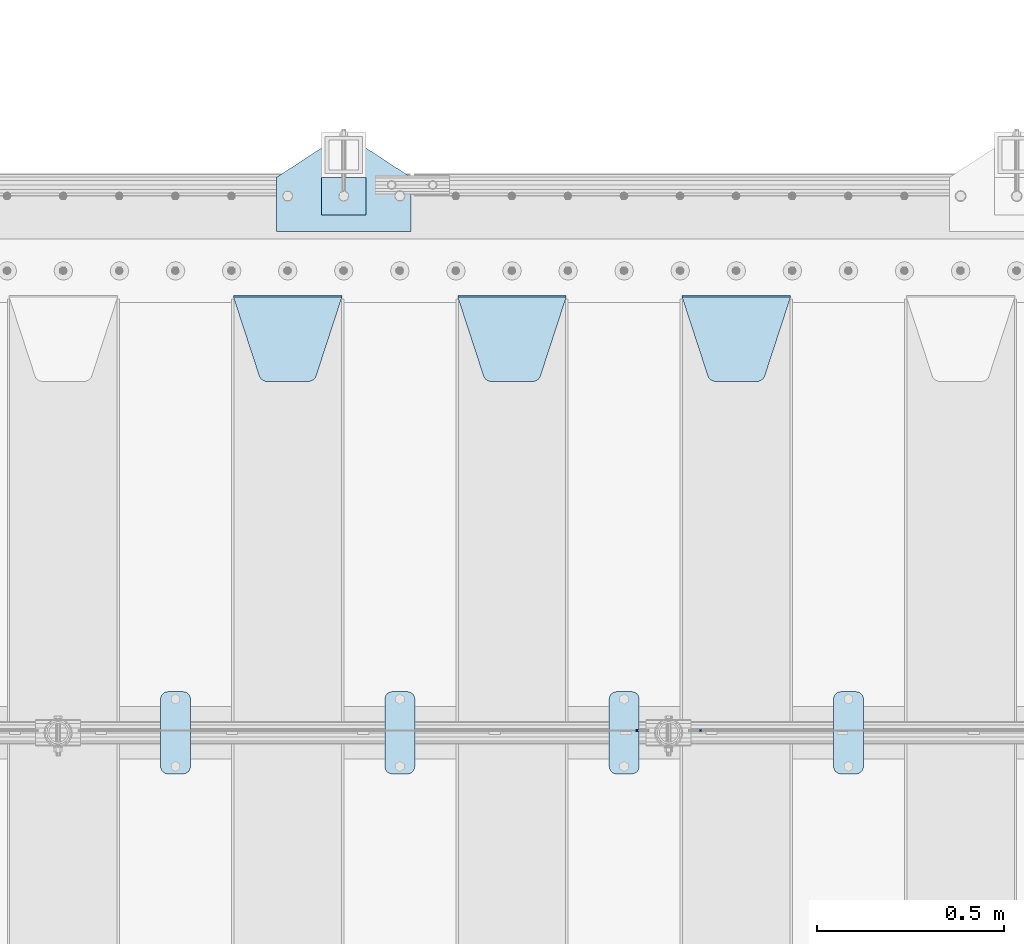
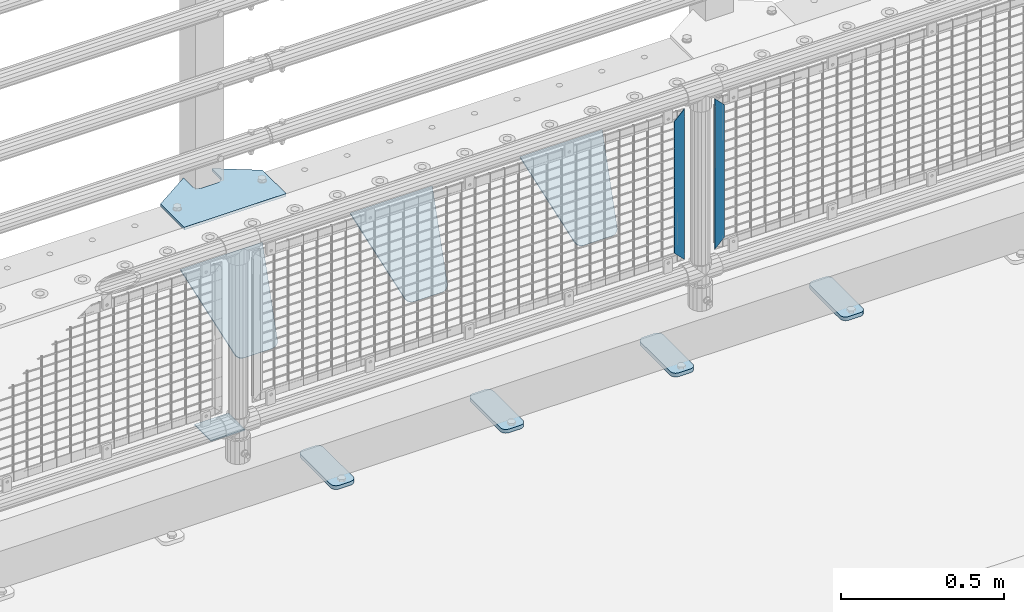
# One storey, part 235 of 270: 11 plates.
"""IFC2X3 building model written with IfcOpenShell, lengths in millimetres."""

from ifc_helpers import new_model, si_unit, frame, origin_with_axes, place, context, subcontext, project, spatial, faceted_brep, material, type_object, element, save


model = new_model("IFC2X3")

# Units and contexts
model_context = context("Model", 3, precision=1e-05, world=origin_with_axes())
body_context = subcontext(model_context, "Body", "Model", "MODEL_VIEW")
ifc_project = project(units=[si_unit("LENGTHUNIT", "METRE", prefix="MILLI"), si_unit("AREAUNIT", "SQUARE_METRE"), si_unit("VOLUMEUNIT", "CUBIC_METRE"), si_unit("MASSUNIT", "GRAM", prefix="KILO"), si_unit("TIMEUNIT", "SECOND"), si_unit("PLANEANGLEUNIT", "RADIAN"), si_unit("SOLIDANGLEUNIT", "STERADIAN"), si_unit("THERMODYNAMICTEMPERATUREUNIT", "DEGREE_CELSIUS"), si_unit("LUMINOUSINTENSITYUNIT", "LUMEN")], contexts=[model_context])

# Site, building, storey
site_placement = place(None, origin_with_axes())
site = spatial("IfcSite", under=ifc_project, at=site_placement, CompositionType="ELEMENT")
building_placement = place(site_placement, origin_with_axes())
building = spatial("IfcBuilding", under=site, at=building_placement, Name="Standard", CompositionType="ELEMENT")
storey_placement = place(building_placement, origin_with_axes())
storey = spatial("IfcBuildingStorey", under=building, at=storey_placement, Name="Undefined", CompositionType="ELEMENT", Elevation=0.0)

# Plates
ifc_material_1 = material(Name="STEEL/S355J2")
plate_type_1 = type_object("IfcPlateType", PredefinedType="NOTDEFINED")
plate_1_placement = place(storey_placement, frame((9370.0, -14995.0, 5.00000000004911), z_axis=(0.0, 1.0, 0.0), x_axis=(1.0, 0.0, 0.0)))
element("IfcPlate", 1, at=plate_1_placement, inside=storey, type_object=plate_type_1, material=ifc_material_1, context=body_context, shape_type="Brep", body=[
    faceted_brep([(0.0, -5.0, 0.0), (2.31396552408114e-06, -5.0, 145.0), (2.31396552408114e-06, 5.0, 145.0), (0.0, 5.0, 0.0), (130.0, -5.0, 230.0), (130.0, 5.0, 230.0), (130.0, -5.0, 180.0), (130.0, 5.0, 180.0), (130.48036798992, -5.0, 175.122741949597), (130.48036798992, 5.0, 175.122741949597), (131.903011687216, -5.0, 170.432914190873), (131.903011687216, 5.0, 170.432914190873), (134.213259692435, -5.0, 166.11074417451), (134.213259692435, 5.0, 166.11074417451), (137.322330470335, -5.0, 162.322330470337), (137.322330470335, 5.0, 162.322330470337), (141.110744174512, -5.0, 159.213259692437), (141.110744174512, 5.0, 159.213259692437), (145.432914190871, -5.0, 156.903011687218), (145.432914190871, 5.0, 156.903011687218), (150.122741949595, -5.0, 155.48036798992), (150.122741949595, 5.0, 155.48036798992), (155.0, -5.0, 155.0), (155.0, 5.0, 155.0), (205.0, -5.0, 155.0), (205.0, 5.0, 155.0), (209.877258050405, -5.0, 155.48036798992), (209.877258050405, 5.0, 155.48036798992), (214.567085809129, -5.0, 156.903011687218), (214.567085809129, 5.0, 156.903011687218), (218.889255825488, -5.0, 159.213259692437), (218.889255825488, 5.0, 159.213259692437), (222.677669529665, -5.0, 162.322330470337), (222.677669529665, 5.0, 162.322330470337), (225.786740307565, -5.0, 166.11074417451), (225.786740307565, 5.0, 166.11074417451), (228.096988312784, -5.0, 170.432914190873), (228.096988312784, 5.0, 170.432914190873), (229.51963201008, -5.0, 175.122741949597), (229.51963201008, 5.0, 175.122741949597), (230.0, -5.0, 180.0), (230.0, 5.0, 180.0), (230.0, -5.0, 230.0), (230.0, 5.0, 230.0), (360.0, -5.0, 145.0), (360.0, 5.0, 145.0), (360.0, -5.0, -7.27595761418343e-12), (360.0, 5.0, -7.27595761418343e-12)], [[[0, 1, 2, 3]], [[1, 4, 5, 2]], [[4, 6, 7, 5]], [[6, 8, 9, 7]], [[8, 10, 11, 9]], [[10, 12, 13, 11]], [[12, 14, 15, 13]], [[14, 16, 17, 15]], [[16, 18, 19, 17]], [[18, 20, 21, 19]], [[20, 22, 23, 21]], [[22, 24, 25, 23]], [[24, 26, 27, 25]], [[26, 28, 29, 27]], [[28, 30, 31, 29]], [[30, 32, 33, 31]], [[32, 34, 35, 33]], [[34, 36, 37, 35]], [[36, 38, 39, 37]], [[38, 40, 41, 39]], [[40, 42, 43, 41]], [[42, 44, 45, 43]], [[44, 46, 47, 45]], [[46, 0, 3, 47]], [[5, 7, 9, 11, 13, 15, 17, 19, 21, 23, 25, 27, 29, 31, 33, 35, 37, 39, 41, 43, 45, 47, 3, 2]], [[46, 44, 42, 40, 38, 36, 34, 32, 30, 28, 26, 24, 22, 20, 18, 16, 14, 12, 10, 8, 6, 4, 1, 0]]]),
])
plate_type_2 = type_object("IfcPlateType", PredefinedType="NOTDEFINED")
plate_2_placement = place(storey_placement, frame((9490.00000000014, -14949.9999999998, -857.500000000002), z_axis=(0.0, 1.0, 0.0), x_axis=(1.0, 0.0, 0.0)))
element("IfcPlate", 2, at=plate_2_placement, inside=storey, type_object=plate_type_2, material=ifc_material_1, context=body_context, shape_type="Brep", body=[
    faceted_brep([(0.0, -2.5, 0.0), (0.0, -2.5, 100.0), (0.0, 2.5, 100.0), (0.0, 2.5, 0.0), (120.0, -2.5, 100.0), (120.0, 2.5, 100.0), (120.0, -2.5, 0.0), (120.0, 2.5, 0.0)], [[[0, 1, 2, 3]], [[1, 4, 5, 2]], [[4, 6, 7, 5]], [[6, 0, 3, 7]], [[5, 7, 3, 2]], [[6, 4, 1, 0]]]),
])
plate_type_3 = type_object("IfcPlateType", PredefinedType="NOTDEFINED")
plate_3_placement = place(storey_placement, frame((10860.0, -16225.5, 21.0199999999977), z_axis=(1.0, 0.0, 0.0), x_axis=(0.0, -1.0, 0.0)))
element("IfcPlate", 3, at=plate_3_placement, inside=storey, type_object=plate_type_3, material=ifc_material_1, context=body_context, shape_type="Brep", body=[
    faceted_brep([(0.0, -7.0, 20.0), (0.0, -7.0, 60.0), (0.0, 7.0, 60.0), (0.0, 7.0, 20.0), (0.384294391937146, -7.0, 63.9018064403208), (0.384294391937146, 7.0, 63.9018064403208), (1.52240934977453, -7.0, 67.6536686473009), (1.52240934977453, 7.0, 67.6536686473009), (3.37060775395003, -7.0, 71.1114046603907), (3.37060775395003, 7.0, 71.1114046603907), (5.8578643762703, -7.0, 74.1421356237297), (5.8578643762703, 7.0, 74.1421356237297), (8.88859533960931, -7.0, 76.62939224605), (8.88859533960931, 7.0, 76.62939224605), (12.3463313526991, -7.0, 78.4775906502255), (12.3463313526991, 7.0, 78.4775906502255), (16.0981935596792, -7.0, 79.6157056080629), (16.0981935596792, 7.0, 79.6157056080629), (20.0, -7.0, 80.0), (20.0, 7.0, 80.0), (200.0, -7.0, 80.0), (200.0, 7.0, 80.0), (203.901806440321, -7.0, 79.6157056080629), (203.901806440321, 7.0, 79.6157056080629), (207.653668647301, -7.0, 78.4775906502255), (207.653668647301, 7.0, 78.4775906502255), (211.111404660391, -7.0, 76.62939224605), (211.111404660391, 7.0, 76.62939224605), (214.142135623733, -7.0, 74.1421356237297), (214.142135623733, 7.0, 74.1421356237297), (216.629392246054, -7.0, 71.1114046603907), (216.629392246054, 7.0, 71.1114046603907), (218.477590650225, -7.0, 67.6536686473009), (218.477590650225, 7.0, 67.6536686473009), (219.615705608063, -7.0, 63.9018064403208), (219.615705608063, 7.0, 63.9018064403208), (220.0, -7.0, 60.0), (220.0, 7.0, 60.0), (220.0, -7.0, 20.0), (220.0, 7.0, 20.0), (219.615705608063, -7.0, 16.0981935596792), (219.615705608063, 7.0, 16.0981935596792), (218.477590650225, -7.0, 12.3463313526991), (218.477590650225, 7.0, 12.3463313526991), (216.629392246054, -7.0, 8.88859533960931), (216.629392246054, 7.0, 8.88859533960931), (214.142135623733, -7.0, 5.8578643762703), (214.142135623733, 7.0, 5.8578643762703), (211.111404660391, -7.0, 3.37060775395003), (211.111404660391, 7.0, 3.37060775395003), (207.653668647301, -7.0, 1.52240934977453), (207.653668647301, 7.0, 1.52240934977453), (203.901806440321, -7.0, 0.384294391937146), (203.901806440321, 7.0, 0.384294391937146), (200.0, -7.0, 0.0), (200.0, 7.0, 0.0), (20.0, -7.0, 0.0), (20.0, 7.0, 0.0), (16.0981935596792, -7.0, 0.384294391937146), (16.0981935596792, 7.0, 0.384294391937146), (12.3463313526991, -7.0, 1.52240934977453), (12.3463313526991, 7.0, 1.52240934977453), (8.88859533960931, -7.0, 3.37060775395003), (8.88859533960931, 7.0, 3.37060775395003), (5.8578643762703, -7.0, 5.8578643762703), (5.8578643762703, 7.0, 5.8578643762703), (3.37060775395003, -7.0, 8.88859533960931), (3.37060775395003, 7.0, 8.88859533960931), (1.52240934977453, -7.0, 12.3463313526991), (1.52240934977453, 7.0, 12.3463313526991), (0.384294391937146, -7.0, 16.0981935596792), (0.384294391937146, 7.0, 16.0981935596792)], [[[0, 1, 2, 3]], [[1, 4, 5, 2]], [[4, 6, 7, 5]], [[6, 8, 9, 7]], [[8, 10, 11, 9]], [[10, 12, 13, 11]], [[12, 14, 15, 13]], [[14, 16, 17, 15]], [[16, 18, 19, 17]], [[18, 20, 21, 19]], [[20, 22, 23, 21]], [[22, 24, 25, 23]], [[24, 26, 27, 25]], [[26, 28, 29, 27]], [[28, 30, 31, 29]], [[30, 32, 33, 31]], [[32, 34, 35, 33]], [[34, 36, 37, 35]], [[36, 38, 39, 37]], [[38, 40, 41, 39]], [[40, 42, 43, 41]], [[42, 44, 45, 43]], [[44, 46, 47, 45]], [[46, 48, 49, 47]], [[48, 50, 51, 49]], [[50, 52, 53, 51]], [[52, 54, 55, 53]], [[54, 56, 57, 55]], [[56, 58, 59, 57]], [[58, 60, 61, 59]], [[60, 62, 63, 61]], [[62, 64, 65, 63]], [[64, 66, 67, 65]], [[66, 68, 69, 67]], [[68, 70, 71, 69]], [[70, 0, 3, 71]], [[5, 7, 9, 11, 13, 15, 17, 19, 21, 23, 25, 27, 29, 31, 33, 35, 37, 39, 41, 43, 45, 47, 49, 51, 53, 55, 57, 59, 61, 63, 65, 67, 69, 71, 3, 2]], [[70, 68, 66, 64, 62, 60, 58, 56, 54, 52, 50, 48, 46, 44, 42, 40, 38, 36, 34, 32, 30, 28, 26, 24, 22, 20, 18, 16, 14, 12, 10, 8, 6, 4, 1, 0]]]),
])
plate_4_placement = place(storey_placement, frame((10260.0, -16225.5, 21.0199999999977), z_axis=(1.0, 0.0, 0.0), x_axis=(0.0, -1.0, 0.0)))
element("IfcPlate", 4, at=plate_4_placement, inside=storey, type_object=plate_type_3, material=ifc_material_1, context=body_context, shape_type="Brep", body=[
    faceted_brep([(0.0, -7.0, 20.0), (0.0, -7.0, 60.0), (0.0, 7.0, 60.0), (0.0, 7.0, 20.0), (0.384294391937146, -7.0, 63.9018064403208), (0.384294391937146, 7.0, 63.9018064403208), (1.52240934977453, -7.0, 67.6536686473009), (1.52240934977453, 7.0, 67.6536686473009), (3.37060775395003, -7.0, 71.1114046603907), (3.37060775395003, 7.0, 71.1114046603907), (5.8578643762703, -7.0, 74.1421356237297), (5.8578643762703, 7.0, 74.1421356237297), (8.88859533960931, -7.0, 76.62939224605), (8.88859533960931, 7.0, 76.62939224605), (12.3463313526991, -7.0, 78.4775906502255), (12.3463313526991, 7.0, 78.4775906502255), (16.0981935596792, -7.0, 79.6157056080629), (16.0981935596792, 7.0, 79.6157056080629), (20.0, -7.0, 80.0), (20.0, 7.0, 80.0), (200.0, -7.0, 80.0), (200.0, 7.0, 80.0), (203.901806440321, -7.0, 79.6157056080629), (203.901806440321, 7.0, 79.6157056080629), (207.653668647301, -7.0, 78.4775906502255), (207.653668647301, 7.0, 78.4775906502255), (211.111404660391, -7.0, 76.62939224605), (211.111404660391, 7.0, 76.62939224605), (214.142135623733, -7.0, 74.1421356237297), (214.142135623733, 7.0, 74.1421356237297), (216.629392246054, -7.0, 71.1114046603907), (216.629392246054, 7.0, 71.1114046603907), (218.477590650225, -7.0, 67.6536686473009), (218.477590650225, 7.0, 67.6536686473009), (219.615705608063, -7.0, 63.9018064403208), (219.615705608063, 7.0, 63.9018064403208), (220.0, -7.0, 60.0), (220.0, 7.0, 60.0), (220.0, -7.0, 20.0), (220.0, 7.0, 20.0), (219.615705608063, -7.0, 16.0981935596792), (219.615705608063, 7.0, 16.0981935596792), (218.477590650225, -7.0, 12.3463313526991), (218.477590650225, 7.0, 12.3463313526991), (216.629392246054, -7.0, 8.88859533960931), (216.629392246054, 7.0, 8.88859533960931), (214.142135623733, -7.0, 5.8578643762703), (214.142135623733, 7.0, 5.8578643762703), (211.111404660391, -7.0, 3.37060775395003), (211.111404660391, 7.0, 3.37060775395003), (207.653668647301, -7.0, 1.52240934977453), (207.653668647301, 7.0, 1.52240934977453), (203.901806440321, -7.0, 0.384294391937146), (203.901806440321, 7.0, 0.384294391937146), (200.0, -7.0, 0.0), (200.0, 7.0, 0.0), (20.0, -7.0, 0.0), (20.0, 7.0, 0.0), (16.0981935596792, -7.0, 0.384294391937146), (16.0981935596792, 7.0, 0.384294391937146), (12.3463313526991, -7.0, 1.52240934977453), (12.3463313526991, 7.0, 1.52240934977453), (8.88859533960931, -7.0, 3.37060775395003), (8.88859533960931, 7.0, 3.37060775395003), (5.8578643762703, -7.0, 5.8578643762703), (5.8578643762703, 7.0, 5.8578643762703), (3.37060775395003, -7.0, 8.88859533960931), (3.37060775395003, 7.0, 8.88859533960931), (1.52240934977453, -7.0, 12.3463313526991), (1.52240934977453, 7.0, 12.3463313526991), (0.384294391937146, -7.0, 16.0981935596792), (0.384294391937146, 7.0, 16.0981935596792)], [[[0, 1, 2, 3]], [[1, 4, 5, 2]], [[4, 6, 7, 5]], [[6, 8, 9, 7]], [[8, 10, 11, 9]], [[10, 12, 13, 11]], [[12, 14, 15, 13]], [[14, 16, 17, 15]], [[16, 18, 19, 17]], [[18, 20, 21, 19]], [[20, 22, 23, 21]], [[22, 24, 25, 23]], [[24, 26, 27, 25]], [[26, 28, 29, 27]], [[28, 30, 31, 29]], [[30, 32, 33, 31]], [[32, 34, 35, 33]], [[34, 36, 37, 35]], [[36, 38, 39, 37]], [[38, 40, 41, 39]], [[40, 42, 43, 41]], [[42, 44, 45, 43]], [[44, 46, 47, 45]], [[46, 48, 49, 47]], [[48, 50, 51, 49]], [[50, 52, 53, 51]], [[52, 54, 55, 53]], [[54, 56, 57, 55]], [[56, 58, 59, 57]], [[58, 60, 61, 59]], [[60, 62, 63, 61]], [[62, 64, 65, 63]], [[64, 66, 67, 65]], [[66, 68, 69, 67]], [[68, 70, 71, 69]], [[70, 0, 3, 71]], [[5, 7, 9, 11, 13, 15, 17, 19, 21, 23, 25, 27, 29, 31, 33, 35, 37, 39, 41, 43, 45, 47, 49, 51, 53, 55, 57, 59, 61, 63, 65, 67, 69, 71, 3, 2]], [[70, 68, 66, 64, 62, 60, 58, 56, 54, 52, 50, 48, 46, 44, 42, 40, 38, 36, 34, 32, 30, 28, 26, 24, 22, 20, 18, 16, 14, 12, 10, 8, 6, 4, 1, 0]]]),
])
plate_5_placement = place(storey_placement, frame((9660.0, -16225.5, 21.0199999999977), z_axis=(1.0, 0.0, 0.0), x_axis=(0.0, -1.0, 0.0)))
element("IfcPlate", 5, at=plate_5_placement, inside=storey, type_object=plate_type_3, material=ifc_material_1, context=body_context, shape_type="Brep", body=[
    faceted_brep([(0.0, -7.0, 20.0), (0.0, -7.0, 60.0), (0.0, 7.0, 60.0), (0.0, 7.0, 20.0), (0.384294391937146, -7.0, 63.9018064403208), (0.384294391937146, 7.0, 63.9018064403208), (1.52240934977453, -7.0, 67.6536686473009), (1.52240934977453, 7.0, 67.6536686473009), (3.37060775395003, -7.0, 71.1114046603907), (3.37060775395003, 7.0, 71.1114046603907), (5.8578643762703, -7.0, 74.1421356237297), (5.8578643762703, 7.0, 74.1421356237297), (8.88859533960931, -7.0, 76.62939224605), (8.88859533960931, 7.0, 76.62939224605), (12.3463313526991, -7.0, 78.4775906502255), (12.3463313526991, 7.0, 78.4775906502255), (16.0981935596792, -7.0, 79.6157056080629), (16.0981935596792, 7.0, 79.6157056080629), (20.0, -7.0, 80.0), (20.0, 7.0, 80.0), (200.0, -7.0, 80.0), (200.0, 7.0, 80.0), (203.901806440321, -7.0, 79.6157056080629), (203.901806440321, 7.0, 79.6157056080629), (207.653668647301, -7.0, 78.4775906502255), (207.653668647301, 7.0, 78.4775906502255), (211.111404660391, -7.0, 76.62939224605), (211.111404660391, 7.0, 76.62939224605), (214.142135623733, -7.0, 74.1421356237297), (214.142135623733, 7.0, 74.1421356237297), (216.629392246054, -7.0, 71.1114046603907), (216.629392246054, 7.0, 71.1114046603907), (218.477590650225, -7.0, 67.6536686473009), (218.477590650225, 7.0, 67.6536686473009), (219.615705608063, -7.0, 63.9018064403208), (219.615705608063, 7.0, 63.9018064403208), (220.0, -7.0, 60.0), (220.0, 7.0, 60.0), (220.0, -7.0, 20.0), (220.0, 7.0, 20.0), (219.615705608063, -7.0, 16.0981935596792), (219.615705608063, 7.0, 16.0981935596792), (218.477590650225, -7.0, 12.3463313526991), (218.477590650225, 7.0, 12.3463313526991), (216.629392246054, -7.0, 8.88859533960931), (216.629392246054, 7.0, 8.88859533960931), (214.142135623733, -7.0, 5.8578643762703), (214.142135623733, 7.0, 5.8578643762703), (211.111404660391, -7.0, 3.37060775395003), (211.111404660391, 7.0, 3.37060775395003), (207.653668647301, -7.0, 1.52240934977453), (207.653668647301, 7.0, 1.52240934977453), (203.901806440321, -7.0, 0.384294391937146), (203.901806440321, 7.0, 0.384294391937146), (200.0, -7.0, 0.0), (200.0, 7.0, 0.0), (20.0, -7.0, 0.0), (20.0, 7.0, 0.0), (16.0981935596792, -7.0, 0.384294391937146), (16.0981935596792, 7.0, 0.384294391937146), (12.3463313526991, -7.0, 1.52240934977453), (12.3463313526991, 7.0, 1.52240934977453), (8.88859533960931, -7.0, 3.37060775395003), (8.88859533960931, 7.0, 3.37060775395003), (5.8578643762703, -7.0, 5.8578643762703), (5.8578643762703, 7.0, 5.8578643762703), (3.37060775395003, -7.0, 8.88859533960931), (3.37060775395003, 7.0, 8.88859533960931), (1.52240934977453, -7.0, 12.3463313526991), (1.52240934977453, 7.0, 12.3463313526991), (0.384294391937146, -7.0, 16.0981935596792), (0.384294391937146, 7.0, 16.0981935596792)], [[[0, 1, 2, 3]], [[1, 4, 5, 2]], [[4, 6, 7, 5]], [[6, 8, 9, 7]], [[8, 10, 11, 9]], [[10, 12, 13, 11]], [[12, 14, 15, 13]], [[14, 16, 17, 15]], [[16, 18, 19, 17]], [[18, 20, 21, 19]], [[20, 22, 23, 21]], [[22, 24, 25, 23]], [[24, 26, 27, 25]], [[26, 28, 29, 27]], [[28, 30, 31, 29]], [[30, 32, 33, 31]], [[32, 34, 35, 33]], [[34, 36, 37, 35]], [[36, 38, 39, 37]], [[38, 40, 41, 39]], [[40, 42, 43, 41]], [[42, 44, 45, 43]], [[44, 46, 47, 45]], [[46, 48, 49, 47]], [[48, 50, 51, 49]], [[50, 52, 53, 51]], [[52, 54, 55, 53]], [[54, 56, 57, 55]], [[56, 58, 59, 57]], [[58, 60, 61, 59]], [[60, 62, 63, 61]], [[62, 64, 65, 63]], [[64, 66, 67, 65]], [[66, 68, 69, 67]], [[68, 70, 71, 69]], [[70, 0, 3, 71]], [[5, 7, 9, 11, 13, 15, 17, 19, 21, 23, 25, 27, 29, 31, 33, 35, 37, 39, 41, 43, 45, 47, 49, 51, 53, 55, 57, 59, 61, 63, 65, 67, 69, 71, 3, 2]], [[70, 68, 66, 64, 62, 60, 58, 56, 54, 52, 50, 48, 46, 44, 42, 40, 38, 36, 34, 32, 30, 28, 26, 24, 22, 20, 18, 16, 14, 12, 10, 8, 6, 4, 1, 0]]]),
])
plate_6_placement = place(storey_placement, frame((9060.0, -16225.5, 21.0199999999977), z_axis=(1.0, 0.0, 0.0), x_axis=(0.0, -1.0, 0.0)))
element("IfcPlate", 6, at=plate_6_placement, inside=storey, type_object=plate_type_3, material=ifc_material_1, context=body_context, shape_type="Brep", body=[
    faceted_brep([(0.0, -7.0, 20.0), (0.0, -7.0, 60.0), (0.0, 7.0, 60.0), (0.0, 7.0, 20.0), (0.384294391937146, -7.0, 63.9018064403208), (0.384294391937146, 7.0, 63.9018064403208), (1.52240934977453, -7.0, 67.6536686473009), (1.52240934977453, 7.0, 67.6536686473009), (3.37060775395003, -7.0, 71.1114046603907), (3.37060775395003, 7.0, 71.1114046603907), (5.8578643762703, -7.0, 74.1421356237297), (5.8578643762703, 7.0, 74.1421356237297), (8.88859533960931, -7.0, 76.62939224605), (8.88859533960931, 7.0, 76.62939224605), (12.3463313526991, -7.0, 78.4775906502255), (12.3463313526991, 7.0, 78.4775906502255), (16.0981935596792, -7.0, 79.6157056080629), (16.0981935596792, 7.0, 79.6157056080629), (20.0, -7.0, 80.0), (20.0, 7.0, 80.0), (200.0, -7.0, 80.0), (200.0, 7.0, 80.0), (203.901806440321, -7.0, 79.6157056080629), (203.901806440321, 7.0, 79.6157056080629), (207.653668647301, -7.0, 78.4775906502255), (207.653668647301, 7.0, 78.4775906502255), (211.111404660391, -7.0, 76.62939224605), (211.111404660391, 7.0, 76.62939224605), (214.142135623733, -7.0, 74.1421356237297), (214.142135623733, 7.0, 74.1421356237297), (216.629392246054, -7.0, 71.1114046603907), (216.629392246054, 7.0, 71.1114046603907), (218.477590650225, -7.0, 67.6536686473009), (218.477590650225, 7.0, 67.6536686473009), (219.615705608063, -7.0, 63.9018064403208), (219.615705608063, 7.0, 63.9018064403208), (220.0, -7.0, 60.0), (220.0, 7.0, 60.0), (220.0, -7.0, 20.0), (220.0, 7.0, 20.0), (219.615705608063, -7.0, 16.0981935596792), (219.615705608063, 7.0, 16.0981935596792), (218.477590650225, -7.0, 12.3463313526991), (218.477590650225, 7.0, 12.3463313526991), (216.629392246054, -7.0, 8.88859533960931), (216.629392246054, 7.0, 8.88859533960931), (214.142135623733, -7.0, 5.8578643762703), (214.142135623733, 7.0, 5.8578643762703), (211.111404660391, -7.0, 3.37060775395003), (211.111404660391, 7.0, 3.37060775395003), (207.653668647301, -7.0, 1.52240934977453), (207.653668647301, 7.0, 1.52240934977453), (203.901806440321, -7.0, 0.384294391937146), (203.901806440321, 7.0, 0.384294391937146), (200.0, -7.0, 0.0), (200.0, 7.0, 0.0), (20.0, -7.0, 0.0), (20.0, 7.0, 0.0), (16.0981935596792, -7.0, 0.384294391937146), (16.0981935596792, 7.0, 0.384294391937146), (12.3463313526991, -7.0, 1.52240934977453), (12.3463313526991, 7.0, 1.52240934977453), (8.88859533960931, -7.0, 3.37060775395003), (8.88859533960931, 7.0, 3.37060775395003), (5.8578643762703, -7.0, 5.8578643762703), (5.8578643762703, 7.0, 5.8578643762703), (3.37060775395003, -7.0, 8.88859533960931), (3.37060775395003, 7.0, 8.88859533960931), (1.52240934977453, -7.0, 12.3463313526991), (1.52240934977453, 7.0, 12.3463313526991), (0.384294391937146, -7.0, 16.0981935596792), (0.384294391937146, 7.0, 16.0981935596792)], [[[0, 1, 2, 3]], [[1, 4, 5, 2]], [[4, 6, 7, 5]], [[6, 8, 9, 7]], [[8, 10, 11, 9]], [[10, 12, 13, 11]], [[12, 14, 15, 13]], [[14, 16, 17, 15]], [[16, 18, 19, 17]], [[18, 20, 21, 19]], [[20, 22, 23, 21]], [[22, 24, 25, 23]], [[24, 26, 27, 25]], [[26, 28, 29, 27]], [[28, 30, 31, 29]], [[30, 32, 33, 31]], [[32, 34, 35, 33]], [[34, 36, 37, 35]], [[36, 38, 39, 37]], [[38, 40, 41, 39]], [[40, 42, 43, 41]], [[42, 44, 45, 43]], [[44, 46, 47, 45]], [[46, 48, 49, 47]], [[48, 50, 51, 49]], [[50, 52, 53, 51]], [[52, 54, 55, 53]], [[54, 56, 57, 55]], [[56, 58, 59, 57]], [[58, 60, 61, 59]], [[60, 62, 63, 61]], [[62, 64, 65, 63]], [[64, 66, 67, 65]], [[66, 68, 69, 67]], [[68, 70, 71, 69]], [[70, 0, 3, 71]], [[5, 7, 9, 11, 13, 15, 17, 19, 21, 23, 25, 27, 29, 31, 33, 35, 37, 39, 41, 43, 45, 47, 49, 51, 53, 55, 57, 59, 61, 63, 65, 67, 69, 71, 3, 2]], [[70, 68, 66, 64, 62, 60, 58, 56, 54, 52, 50, 48, 46, 44, 42, 40, 38, 36, 34, 32, 30, 28, 26, 24, 22, 20, 18, 16, 14, 12, 10, 8, 6, 4, 1, 0]]]),
])
ifc_material_2 = material(Name="STEEL/S355N")
plate_type_4 = type_object("IfcPlateType", PredefinedType="NOTDEFINED")
plate_7_placement = place(storey_placement, frame((10455.0, -15168.2322330441, -1.76776695296576), z_axis=(0.0, -0.707106781186548, -0.707106781186547), x_axis=(1.0, 0.0, 0.0)))
element("IfcPlate", 7, at=plate_7_placement, inside=storey, type_object=plate_type_4, material=ifc_material_2, context=body_context, shape_type="Brep", body=[
    faceted_brep([(0.0, -2.5, 0.0), (69.345504679477, -2.5, 300.171731424831), (69.345504679477, 2.5, 300.171731424831), (0.0, 2.5, 0.0), (70.9274061199576, -2.5, 304.8974424154), (70.9274061199576, 2.5, 304.8974424154), (73.3818627772307, -2.49999999999818, 309.234538108527), (73.3818627772307, 2.50000000000182, 309.234538108527), (76.6187032999551, -2.5, 313.023683126103), (76.6187032999551, 2.5, 313.023683126103), (80.5190132704993, -2.5, 316.125672595372), (80.5190132704993, 2.50000000000182, 316.125672595372), (84.9395038596849, -2.49999999999818, 318.426546230476), (84.9395038596849, 2.5, 318.426546230476), (89.7177759439219, -2.49999999999818, 319.841774983275), (89.7177759439219, 2.50000000000182, 319.841774983275), (94.678286292652, -2.5, 320.319366455078), (94.678286292652, 2.5, 320.319366455078), (195.321713707348, -2.5, 320.319366455078), (195.321713707348, 2.5, 320.319366455078), (200.282224056078, -2.49999999999818, 319.841774983275), (200.282224056078, 2.50000000000182, 319.841774983275), (205.060496140315, -2.5, 318.426546230476), (205.060496140315, 2.5, 318.426546230476), (209.480986729501, -2.5, 316.12567259537), (209.480986729501, 2.50000000000182, 316.12567259537), (213.381296700045, -2.5, 313.023683126103), (213.381296700045, 2.5, 313.023683126103), (216.618137222769, -2.49999999999818, 309.234538108525), (216.618137222769, 2.50000000000182, 309.234538108527), (219.072593880042, -2.49999999999818, 304.897442415398), (219.072593880042, 2.50000000000182, 304.897442415397), (220.654495320523, -2.5, 300.171731424831), (220.654495320523, 2.5, 300.171731424831), (290.0, -2.49999999999818, 0.0), (290.0, 2.5, 0.0)], [[[0, 1, 2, 3]], [[1, 4, 5, 2]], [[4, 6, 7, 5]], [[6, 8, 9, 7]], [[8, 10, 11, 9]], [[10, 12, 13, 11]], [[12, 14, 15, 13]], [[14, 16, 17, 15]], [[16, 18, 19, 17]], [[18, 20, 21, 19]], [[20, 22, 23, 21]], [[22, 24, 25, 23]], [[24, 26, 27, 25]], [[26, 28, 29, 27]], [[28, 30, 31, 29]], [[30, 32, 33, 31]], [[32, 34, 35, 33]], [[34, 0, 3, 35]], [[5, 7, 9, 11, 13, 15, 17, 19, 21, 23, 25, 27, 29, 31, 33, 35, 3, 2]], [[34, 32, 30, 28, 26, 24, 22, 20, 18, 16, 14, 12, 10, 8, 6, 4, 1, 0]]]),
])
plate_8_placement = place(storey_placement, frame((9855.0, -15168.2322330441, -1.76776695296576), z_axis=(0.0, -0.707106781186548, -0.707106781186547), x_axis=(1.0, 0.0, 0.0)))
element("IfcPlate", 8, at=plate_8_placement, inside=storey, type_object=plate_type_4, material=ifc_material_2, context=body_context, shape_type="Brep", body=[
    faceted_brep([(0.0, -2.5, 0.0), (69.345504679477, -2.5, 300.171731424831), (69.345504679477, 2.5, 300.171731424831), (0.0, 2.5, 0.0), (70.9274061199576, -2.5, 304.8974424154), (70.9274061199576, 2.5, 304.8974424154), (73.3818627772307, -2.49999999999818, 309.234538108527), (73.3818627772307, 2.50000000000182, 309.234538108527), (76.6187032999551, -2.5, 313.023683126103), (76.6187032999551, 2.5, 313.023683126103), (80.5190132704993, -2.5, 316.125672595372), (80.5190132704993, 2.50000000000182, 316.125672595372), (84.9395038596849, -2.49999999999818, 318.426546230476), (84.9395038596849, 2.5, 318.426546230476), (89.7177759439219, -2.49999999999818, 319.841774983275), (89.7177759439219, 2.50000000000182, 319.841774983275), (94.678286292652, -2.5, 320.319366455078), (94.678286292652, 2.5, 320.319366455078), (195.321713707348, -2.5, 320.319366455078), (195.321713707348, 2.5, 320.319366455078), (200.282224056078, -2.49999999999818, 319.841774983275), (200.282224056078, 2.50000000000182, 319.841774983275), (205.060496140315, -2.5, 318.426546230476), (205.060496140315, 2.5, 318.426546230476), (209.480986729501, -2.5, 316.12567259537), (209.480986729501, 2.50000000000182, 316.12567259537), (213.381296700045, -2.5, 313.023683126103), (213.381296700045, 2.5, 313.023683126103), (216.618137222769, -2.49999999999818, 309.234538108525), (216.618137222769, 2.50000000000182, 309.234538108527), (219.072593880042, -2.49999999999818, 304.897442415398), (219.072593880042, 2.50000000000182, 304.897442415397), (220.654495320523, -2.5, 300.171731424831), (220.654495320523, 2.5, 300.171731424831), (290.0, -2.49999999999818, 0.0), (290.0, 2.5, 0.0)], [[[0, 1, 2, 3]], [[1, 4, 5, 2]], [[4, 6, 7, 5]], [[6, 8, 9, 7]], [[8, 10, 11, 9]], [[10, 12, 13, 11]], [[12, 14, 15, 13]], [[14, 16, 17, 15]], [[16, 18, 19, 17]], [[18, 20, 21, 19]], [[20, 22, 23, 21]], [[22, 24, 25, 23]], [[24, 26, 27, 25]], [[26, 28, 29, 27]], [[28, 30, 31, 29]], [[30, 32, 33, 31]], [[32, 34, 35, 33]], [[34, 0, 3, 35]], [[5, 7, 9, 11, 13, 15, 17, 19, 21, 23, 25, 27, 29, 31, 33, 35, 3, 2]], [[34, 32, 30, 28, 26, 24, 22, 20, 18, 16, 14, 12, 10, 8, 6, 4, 1, 0]]]),
])
plate_9_placement = place(storey_placement, frame((9255.0, -15168.2322330441, -1.76776695296576), z_axis=(0.0, -0.707106781186548, -0.707106781186547), x_axis=(1.0, 0.0, 0.0)))
element("IfcPlate", 9, at=plate_9_placement, inside=storey, type_object=plate_type_4, material=ifc_material_2, context=body_context, shape_type="Brep", body=[
    faceted_brep([(0.0, -2.5, 0.0), (69.345504679477, -2.5, 300.171731424831), (69.345504679477, 2.5, 300.171731424831), (0.0, 2.5, 0.0), (70.9274061199576, -2.5, 304.8974424154), (70.9274061199576, 2.5, 304.8974424154), (73.3818627772307, -2.49999999999818, 309.234538108527), (73.3818627772307, 2.50000000000182, 309.234538108527), (76.6187032999551, -2.5, 313.023683126103), (76.6187032999551, 2.5, 313.023683126103), (80.5190132704993, -2.5, 316.125672595372), (80.5190132704993, 2.50000000000182, 316.125672595372), (84.9395038596849, -2.49999999999818, 318.426546230476), (84.9395038596849, 2.5, 318.426546230476), (89.7177759439219, -2.49999999999818, 319.841774983275), (89.7177759439219, 2.50000000000182, 319.841774983275), (94.678286292652, -2.5, 320.319366455078), (94.678286292652, 2.5, 320.319366455078), (195.321713707348, -2.5, 320.319366455078), (195.321713707348, 2.5, 320.319366455078), (200.282224056078, -2.49999999999818, 319.841774983275), (200.282224056078, 2.50000000000182, 319.841774983275), (205.060496140315, -2.5, 318.426546230476), (205.060496140315, 2.5, 318.426546230476), (209.480986729501, -2.5, 316.12567259537), (209.480986729501, 2.50000000000182, 316.12567259537), (213.381296700045, -2.5, 313.023683126103), (213.381296700045, 2.5, 313.023683126103), (216.618137222769, -2.49999999999818, 309.234538108525), (216.618137222769, 2.50000000000182, 309.234538108527), (219.072593880042, -2.49999999999818, 304.897442415398), (219.072593880042, 2.50000000000182, 304.897442415397), (220.654495320523, -2.5, 300.171731424831), (220.654495320523, 2.5, 300.171731424831), (290.0, -2.49999999999818, 0.0), (290.0, 2.5, 0.0)], [[[0, 1, 2, 3]], [[1, 4, 5, 2]], [[4, 6, 7, 5]], [[6, 8, 9, 7]], [[8, 10, 11, 9]], [[10, 12, 13, 11]], [[12, 14, 15, 13]], [[14, 16, 17, 15]], [[16, 18, 19, 17]], [[18, 20, 21, 19]], [[20, 22, 23, 21]], [[22, 24, 25, 23]], [[24, 26, 27, 25]], [[26, 28, 29, 27]], [[28, 30, 31, 29]], [[30, 32, 33, 31]], [[32, 34, 35, 33]], [[34, 0, 3, 35]], [[5, 7, 9, 11, 13, 15, 17, 19, 21, 23, 25, 27, 29, 31, 33, 35, 3, 2]], [[34, 32, 30, 28, 26, 24, 22, 20, 18, 16, 14, 12, 10, 8, 6, 4, 1, 0]]]),
])
ifc_material_3 = material(Name="Misc_Undefined")
plate_type_5 = type_object("IfcPlateType", PredefinedType="NOTDEFINED")
plate_10_placement = place(storey_placement, frame((10507.509713541, -16329.5, 879.519963133601), z_axis=(-0.707008801899319, 0.0, -0.707204746899291), x_axis=(-0.707204746899302, 0.0, 0.707008801899308)))
element("IfcPlate", 10, at=plate_10_placement, inside=storey, type_object=plate_type_5, material=ifc_material_3, context=body_context, shape_type="Brep", body=[
    faceted_brep([(0.0, -1.5, 0.0), (-348.552185058599, -1.5, 348.655029296877), (-348.552185058599, 1.5, 348.655029296877), (0.0, 1.5, 0.0), (-348.544891357427, -1.5, 398.152496337894), (-348.544891357427, 1.5, 398.152496337894), (49.50439453125, -1.5, 8.00355337560177e-11), (49.50439453125, 1.5, 8.00355337560177e-11)], [[[0, 1, 2, 3]], [[1, 4, 5, 2]], [[4, 6, 7, 5]], [[6, 0, 3, 7]], [[5, 7, 3, 2]], [[6, 4, 1, 0]]]),
])
plate_11_placement = place(storey_placement, frame((10330.4996874836, -16329.5, 879.52), z_axis=(0.707103624179499, 0.0, -0.707109938179501), x_axis=(0.707109938179513, 0.0, 0.707103624179487)))
element("IfcPlate", 11, at=plate_11_placement, inside=storey, type_object=plate_type_5, material=ifc_material_3, context=body_context, shape_type="Brep", body=[
    faceted_brep([(0.0, -1.5, 0.0), (-348.605163574224, -1.5, 348.602081298828), (-348.605163574224, 1.5, 348.602081298828), (0.0, 1.5, 0.0), (-348.605163574226, -1.5, 398.099334716795), (-348.605163574226, 1.5, 398.099334716795), (49.4976959228497, -1.5, -7.27595761418343e-12), (49.4976959228497, 1.5, -7.27595761418343e-12)], [[[0, 1, 2, 3]], [[1, 4, 5, 2]], [[4, 6, 7, 5]], [[6, 0, 3, 7]], [[5, 7, 3, 2]], [[6, 4, 1, 0]]]),
])

save(model, "model.ifc")
